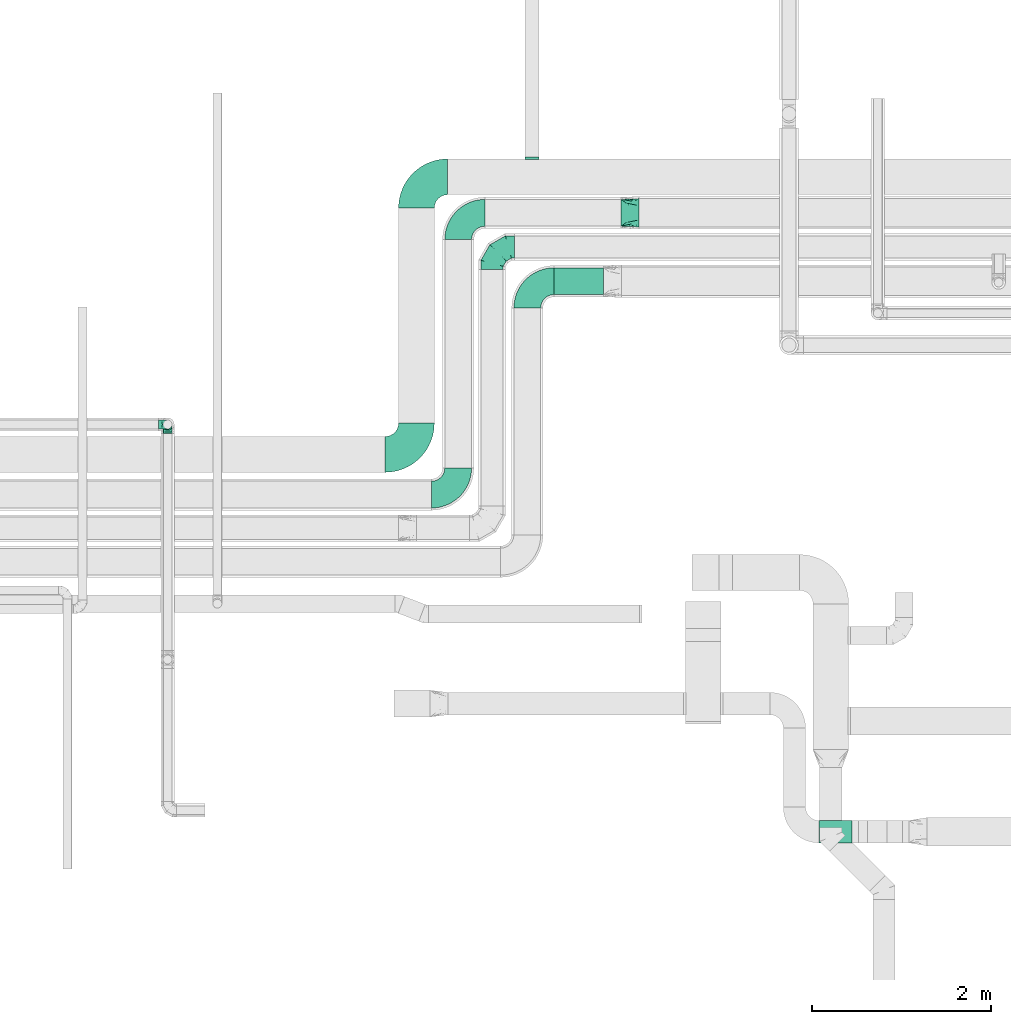
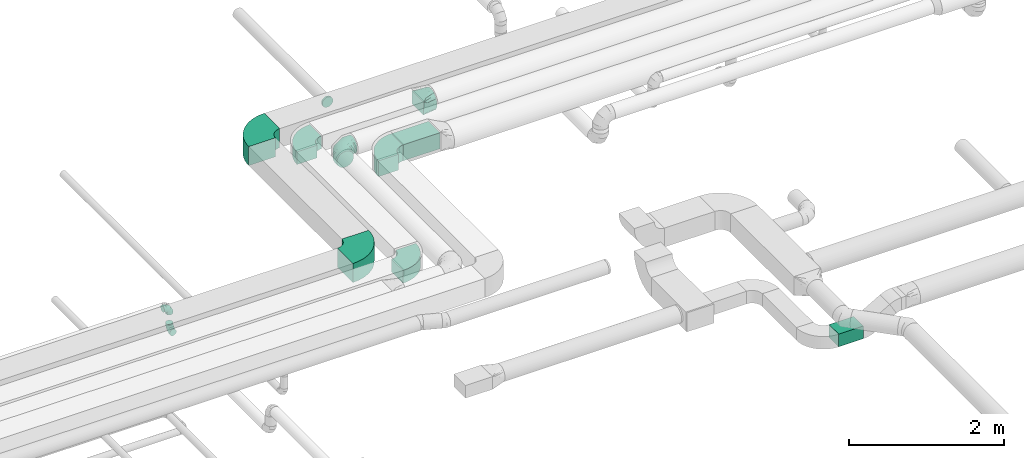
# One storey, part 44 of 92: 10 flow fittings, 2 flow segments.
"""IFC2X3 building model written with IfcOpenShell, lengths in millimetres."""

from ifc_helpers import new_model, entity, si_unit, converted_unit, derived_unit, direction, frame, frame_2d, origin, origin_2d_with_axis, place, context, subcontext, project, spatial, polyline, circle_curve, parameter, trimmed, segment, composite_curve, rectangle, outline, extrude, faceted_brep, source, transform, mapped, material, type_object, type_shapes, element, save


model = new_model("IFC2X3")

# Units and contexts
model_context = context("Model", 3, precision=0.01, world=origin(), true_north=direction((6.12303176911189e-17, 1.0)))
body_context = subcontext(model_context, "Body", "Model", "MODEL_VIEW")
ifc_project = project(units=[si_unit("LENGTHUNIT", "METRE", prefix="MILLI"), si_unit("AREAUNIT", "SQUARE_METRE"), si_unit("VOLUMEUNIT", "CUBIC_METRE"), converted_unit("PLANEANGLEUNIT", "DEGREE", entity("IfcRatioMeasure", 0.0174532925199433), si_unit("PLANEANGLEUNIT", "RADIAN"), dimensions=[0, 0, 0, 0, 0, 0, 0]), si_unit("MASSUNIT", "GRAM", prefix="KILO"), derived_unit("MASSDENSITYUNIT", [(si_unit("MASSUNIT", "GRAM", prefix="KILO"), 1), (si_unit("LENGTHUNIT", "METRE"), -3)]), derived_unit("MOMENTOFINERTIAUNIT", [(si_unit("LENGTHUNIT", "METRE"), 4)]), si_unit("TIMEUNIT", "SECOND"), si_unit("FREQUENCYUNIT", "HERTZ"), si_unit("THERMODYNAMICTEMPERATUREUNIT", "DEGREE_CELSIUS"), derived_unit("THERMALTRANSMITTANCEUNIT", [(si_unit("MASSUNIT", "GRAM", prefix="KILO"), 1), (si_unit("THERMODYNAMICTEMPERATUREUNIT", "KELVIN"), -1), (si_unit("TIMEUNIT", "SECOND"), -3)]), derived_unit("VOLUMETRICFLOWRATEUNIT", [(si_unit("LENGTHUNIT", "METRE"), 3), (si_unit("TIMEUNIT", "SECOND"), -1)]), derived_unit("MASSFLOWRATEUNIT", [(si_unit("MASSUNIT", "GRAM", prefix="KILO"), 1), (si_unit("TIMEUNIT", "SECOND"), -1)]), derived_unit("ROTATIONALFREQUENCYUNIT", [(si_unit("TIMEUNIT", "SECOND"), -1)]), si_unit("ELECTRICCURRENTUNIT", "AMPERE"), si_unit("ELECTRICVOLTAGEUNIT", "VOLT"), si_unit("POWERUNIT", "WATT"), si_unit("FORCEUNIT", "NEWTON", prefix="KILO"), si_unit("ILLUMINANCEUNIT", "LUX"), si_unit("LUMINOUSFLUXUNIT", "LUMEN"), si_unit("LUMINOUSINTENSITYUNIT", "CANDELA"), derived_unit("USERDEFINED", [(si_unit("MASSUNIT", "GRAM", prefix="KILO"), -1), (si_unit("LENGTHUNIT", "METRE"), -2), (si_unit("TIMEUNIT", "SECOND"), 3), (si_unit("LUMINOUSFLUXUNIT", "LUMEN"), 1)]), derived_unit("LINEARVELOCITYUNIT", [(si_unit("LENGTHUNIT", "METRE"), 1), (si_unit("TIMEUNIT", "SECOND"), -1)]), si_unit("PRESSUREUNIT", "PASCAL"), derived_unit("USERDEFINED", [(si_unit("LENGTHUNIT", "METRE"), -2), (si_unit("MASSUNIT", "GRAM", prefix="KILO"), 1), (si_unit("TIMEUNIT", "SECOND"), -2)]), derived_unit("LINEARFORCEUNIT", [(si_unit("MASSUNIT", "GRAM", prefix="KILO"), 1), (si_unit("LENGTHUNIT", "METRE"), 1), (si_unit("TIMEUNIT", "SECOND"), -2), (si_unit("LENGTHUNIT", "METRE"), -1)]), derived_unit("PLANARFORCEUNIT", [(si_unit("MASSUNIT", "GRAM", prefix="KILO"), 1), (si_unit("LENGTHUNIT", "METRE"), 1), (si_unit("TIMEUNIT", "SECOND"), -2), (si_unit("LENGTHUNIT", "METRE"), -2)])], contexts=[model_context])

# Site, building, storey
site_placement = place(None, origin())
site = spatial("IfcSite", under=ifc_project, at=site_placement, CompositionType="ELEMENT")
building_placement = place(site_placement, origin())
building = spatial("IfcBuilding", under=site, at=building_placement, CompositionType="ELEMENT")
storey_placement = place(building_placement, frame((0.0, 0.0, 4200.0)))
storey = spatial("IfcBuildingStorey", under=building, at=storey_placement, CompositionType="ELEMENT", Elevation=4200.0)

# Flow segments
duct_segment_type = type_object("IfcDuctSegmentType", PredefinedType="NOTDEFINED")
flow_segment_1_placement = place(storey_placement, frame((26228.23, 8674.98, 2950.0)))
element("IfcFlowSegment", 1, at=flow_segment_1_placement, inside=storey, type_object=duct_segment_type, context=body_context, shape_type="SweptSolid", body=[
    extrude(rectangle(XDim=368.802712652483, YDim=249.999999999999, at=origin_2d_with_axis()), frame((184.4, 125.0, 0.0)), (0.0, 0.0, 1.0), 200.0),
])
flow_segment_2_placement = place(storey_placement, frame((23265.08, 14807.0, 3200.0)))
element("IfcFlowSegment", 2, at=flow_segment_2_placement, inside=storey, type_object=duct_segment_type, context=body_context, shape_type="SweptSolid", body=[
    extrude(rectangle(XDim=554.647530360597, YDim=299.999999999999, at=origin_2d_with_axis()), frame((277.32, 150.0, 0.0)), (0.0, 0.0, 1.0), 249.999999999999),
])

# Flow fittings
ifc_material = material()
duct_fitting_type_1 = type_object("IfcDuctFittingType", PredefinedType="NOTDEFINED", material=ifc_material)
shared_shape_1 = source(origin(), body_context, "Body", "Brep", [
    faceted_brep([(-100.0, 0.0, -50.0), (-100.0, -12.94, -48.3), (-100.0, -25.0, -43.3), (-100.0, -35.36, -35.36), (-100.0, -43.3, -25.0), (-100.0, -48.3, -12.94), (-100.0, -50.0, 0.0), (-100.0, -48.3, 12.94), (-100.0, -43.3, 25.0), (-100.0, -35.36, 35.36), (-100.0, -25.0, 43.3), (-100.0, -12.94, 48.3), (-100.0, 0.0, 50.0), (-100.0, 12.94, 48.3), (-100.0, 25.0, 43.3), (-100.0, 35.36, 35.36), (-100.0, 43.3, 25.0), (-100.0, 48.3, 12.94), (-100.0, 50.0, 0.0), (-100.0, 48.3, -12.94), (-100.0, 43.3, -25.0), (-100.0, 35.36, -35.36), (-100.0, 25.0, -43.3), (-100.0, 12.94, -48.3), (-76.67, 12.94, 48.3), (-79.9, 25.0, 43.3), (-73.21, 0.0, 50.0), (-82.68, 35.36, 35.36), (-86.15, 48.3, 12.94), (-86.6, 50.0, 0.0), (-84.81, 43.3, 25.0), (-84.81, 43.3, -25.0), (-82.68, 35.36, -35.36), (-86.15, 48.3, -12.94), (-76.67, 12.94, -48.3), (-73.21, 0.0, -50.0), (-79.9, 25.0, -43.3), (-69.74, -12.94, -48.3), (-66.51, -25.0, -43.3), (-63.73, -35.36, -35.36), (-61.6, -43.3, -25.0), (-60.26, -48.3, -12.94), (-59.81, -50.0, 0.0), (-60.26, -48.3, 12.94), (-61.6, -43.3, 25.0), (-63.73, -35.36, 35.36), (-66.51, -25.0, 43.3), (-69.74, -12.94, 48.3), (-36.27, 36.27, 48.3), (-45.1, 45.1, 43.3), (-26.79, 26.79, 50.0), (-52.68, 52.68, 35.36), (-58.49, 58.49, 25.0), (-62.15, 62.15, 12.94), (-63.4, 63.4, 0.0), (-62.15, 62.15, -12.94), (-58.49, 58.49, -25.0), (-52.68, 52.68, -35.36), (-36.27, 36.27, -48.3), (-26.79, 26.79, -50.0), (-45.1, 45.1, -43.3), (-17.32, 17.32, -48.3), (-8.49, 8.49, -43.3), (-0.91, 0.91, -35.36), (4.9, -4.9, -25.0), (8.56, -8.56, -12.94), (9.81, -9.81, 0.0), (8.56, -8.56, 12.94), (4.9, -4.9, 25.0), (-0.91, 0.91, 35.36), (-8.49, 8.49, 43.3), (-17.32, 17.32, 48.3), (-12.94, 76.67, 48.3), (-25.0, 79.9, 43.3), (0.0, 73.21, 50.0), (-35.36, 82.68, 35.36), (-43.3, 84.81, 25.0), (-48.3, 86.15, 12.94), (-50.0, 86.6, 0.0), (-48.3, 86.15, -12.94), (-43.3, 84.81, -25.0), (-35.36, 82.68, -35.36), (-12.94, 76.67, -48.3), (0.0, 73.21, -50.0), (-25.0, 79.9, -43.3), (12.94, 69.74, -48.3), (25.0, 66.51, -43.3), (35.36, 63.73, -35.36), (43.3, 61.6, -25.0), (48.3, 60.26, -12.94), (50.0, 59.81, 0.0), (48.3, 60.26, 12.94), (43.3, 61.6, 25.0), (35.36, 63.73, 35.36), (25.0, 66.51, 43.3), (12.94, 69.74, 48.3), (-12.94, 100.0, -48.3), (-25.0, 100.0, -43.3), (-35.36, 100.0, -35.36), (-43.3, 100.0, -25.0), (-48.3, 100.0, -12.94), (-50.0, 100.0, 0.0), (-48.3, 100.0, 12.94), (-43.3, 100.0, 25.0), (-35.36, 100.0, 35.36), (-25.0, 100.0, 43.3), (-12.94, 100.0, 48.3), (0.0, 100.0, 50.0), (12.94, 100.0, 48.3), (25.0, 100.0, 43.3), (35.36, 100.0, 35.36), (43.3, 100.0, 25.0), (48.3, 100.0, 12.94), (50.0, 100.0, 0.0), (48.3, 100.0, -12.94), (43.3, 100.0, -25.0), (35.36, 100.0, -35.36), (25.0, 100.0, -43.3), (12.94, 100.0, -48.3), (0.0, 100.0, -50.0)], [[[0, 1, 2, 3, 4, 5, 6, 7, 8, 9, 10, 11, 12, 13, 14, 15, 16, 17, 18, 19, 20, 21, 22, 23]], [[24, 25, 14, 13]], [[26, 24, 13, 12]], [[14, 25, 27, 15]], [[28, 29, 18, 17]], [[30, 28, 17, 16]], [[15, 27, 30, 16]], [[20, 31, 32, 21]], [[33, 31, 20, 19]], [[18, 29, 33, 19]], [[34, 35, 0, 23]], [[36, 34, 23, 22]], [[32, 36, 22, 21]], [[2, 1, 37, 38]], [[3, 2, 38, 39]], [[0, 35, 37, 1]], [[5, 4, 40, 41]], [[6, 5, 41, 42]], [[3, 39, 40, 4]], [[6, 42, 43, 7]], [[7, 43, 44, 8]], [[8, 44, 45, 9]], [[10, 46, 47, 11]], [[11, 47, 26, 12]], [[10, 9, 45, 46]], [[48, 49, 25, 24]], [[50, 48, 24, 26]], [[27, 25, 49, 51]], [[52, 53, 28, 30]], [[51, 52, 30, 27]], [[29, 28, 53, 54]], [[55, 56, 31, 33]], [[54, 55, 33, 29]], [[57, 32, 31, 56]], [[58, 59, 35, 34]], [[60, 58, 34, 36]], [[57, 60, 36, 32]], [[37, 35, 59, 61]], [[38, 37, 61, 62]], [[39, 38, 62, 63]], [[41, 40, 64, 65]], [[42, 41, 65, 66]], [[63, 64, 40, 39]], [[43, 42, 66, 67]], [[44, 43, 67, 68]], [[68, 69, 45, 44]], [[46, 45, 69, 70]], [[47, 46, 70, 71]], [[26, 47, 71, 50]], [[72, 73, 49, 48]], [[74, 72, 48, 50]], [[51, 49, 73, 75]], [[76, 77, 53, 52]], [[75, 76, 52, 51]], [[54, 53, 77, 78]], [[79, 80, 56, 55]], [[78, 79, 55, 54]], [[81, 57, 56, 80]], [[82, 83, 59, 58]], [[84, 82, 58, 60]], [[81, 84, 60, 57]], [[61, 59, 83, 85]], [[62, 61, 85, 86]], [[63, 62, 86, 87]], [[65, 64, 88, 89]], [[66, 65, 89, 90]], [[87, 88, 64, 63]], [[67, 66, 90, 91]], [[68, 67, 91, 92]], [[92, 93, 69, 68]], [[70, 69, 93, 94]], [[71, 70, 94, 95]], [[50, 71, 95, 74]], [[96, 97, 98, 99, 100, 101, 102, 103, 104, 105, 106, 107, 108, 109, 110, 111, 112, 113, 114, 115, 116, 117, 118, 119]], [[72, 74, 107, 106]], [[73, 72, 106, 105]], [[75, 73, 105, 104]], [[77, 76, 103, 102]], [[78, 77, 102, 101]], [[75, 104, 103, 76]], [[78, 101, 100, 79]], [[79, 100, 99, 80]], [[80, 99, 98, 81]], [[96, 119, 83, 82]], [[97, 96, 82, 84]], [[84, 81, 98, 97]], [[83, 119, 118, 85]], [[85, 118, 117, 86]], [[86, 117, 116, 87]], [[88, 115, 114, 89]], [[89, 114, 113, 90]], [[87, 116, 115, 88]], [[91, 90, 113, 112]], [[92, 91, 112, 111]], [[93, 92, 111, 110]], [[95, 94, 109, 108]], [[74, 95, 108, 107]], [[110, 109, 94, 93]]]),
])
type_shapes(duct_fitting_type_1, [shared_shape_1])
for number, where, z_axis, x_axis in (
    (3, (18942.06, 13354.28, 2950.0), (1.0, 0.0, 0.0), (0.0, 1.0, 0.0)),
    (4, (18942.06, 13354.28, 3300.0), (0.0, -1.0, 0.0), (0.0, 0.0, 1.0)),
):
    element("IfcFlowFitting", number, at=place(storey_placement, frame(where, z_axis=z_axis, x_axis=x_axis)), inside=storey, type_object=duct_fitting_type_1, material=ifc_material, context=body_context, shape_type="MappedRepresentation", body=[
        mapped(shared_shape_1, transform((0.0, 0.0, 0.0), scale=1.0)),
    ])
duct_fitting_type_2 = type_object("IfcDuctFittingType", PredefinedType="NOTDEFINED", material=ifc_material)
shared_shape_2 = source(origin(), body_context, "Body", "Brep", [
    faceted_brep([(-250.0, 0.0, -125.0), (-250.0, -32.35, -120.74), (-250.0, -62.5, -108.25), (-250.0, -88.39, -88.39), (-250.0, -108.25, -62.5), (-250.0, -120.74, -32.35), (-250.0, -125.0, 0.0), (-250.0, -120.74, 32.35), (-250.0, -108.25, 62.5), (-250.0, -88.39, 88.39), (-250.0, -62.5, 108.25), (-250.0, -32.35, 120.74), (-250.0, 0.0, 125.0), (-250.0, 32.35, 120.74), (-250.0, 62.5, 108.25), (-250.0, 88.39, 88.39), (-250.0, 108.25, 62.5), (-250.0, 120.74, 32.35), (-250.0, 125.0, 0.0), (-250.0, 120.74, -32.35), (-250.0, 108.25, -62.5), (-250.0, 88.39, -88.39), (-250.0, 62.5, -108.25), (-250.0, 32.35, -120.74), (-191.68, 32.35, 120.74), (-199.76, 62.5, 108.25), (-183.01, 0.0, 125.0), (-206.7, 88.39, 88.39), (-215.37, 120.74, 32.35), (-216.51, 125.0, 0.0), (-212.02, 108.25, 62.5), (-212.02, 108.25, -62.5), (-206.7, 88.39, -88.39), (-215.37, 120.74, -32.35), (-191.68, 32.35, -120.74), (-183.01, 0.0, -125.0), (-199.76, 62.5, -108.25), (-174.34, -32.35, -120.74), (-166.27, -62.5, -108.25), (-159.33, -88.39, -88.39), (-154.01, -108.25, -62.5), (-150.66, -120.74, -32.35), (-149.52, -125.0, 0.0), (-150.66, -120.74, 32.35), (-154.01, -108.25, 62.5), (-159.33, -88.39, 88.39), (-166.27, -62.5, 108.25), (-174.34, -32.35, 120.74), (-90.67, 90.67, 120.74), (-112.74, 112.74, 108.25), (-66.99, 66.99, 125.0), (-131.69, 131.69, 88.39), (-146.23, 146.23, 62.5), (-155.38, 155.38, 32.35), (-158.49, 158.49, 0.0), (-155.38, 155.38, -32.35), (-146.23, 146.23, -62.5), (-131.69, 131.69, -88.39), (-90.67, 90.67, -120.74), (-66.99, 66.99, -125.0), (-112.74, 112.74, -108.25), (-43.3, 43.3, -120.74), (-21.23, 21.23, -108.25), (-2.28, 2.28, -88.39), (12.26, -12.26, -62.5), (21.4, -21.4, -32.35), (24.52, -24.52, 0.0), (21.4, -21.4, 32.35), (12.26, -12.26, 62.5), (-2.28, 2.28, 88.39), (-21.23, 21.23, 108.25), (-43.3, 43.3, 120.74), (-32.35, 191.68, 120.74), (-62.5, 199.76, 108.25), (0.0, 183.01, 125.0), (-88.39, 206.7, 88.39), (-108.25, 212.02, 62.5), (-120.74, 215.37, 32.35), (-125.0, 216.51, 0.0), (-120.74, 215.37, -32.35), (-108.25, 212.02, -62.5), (-88.39, 206.7, -88.39), (-32.35, 191.68, -120.74), (0.0, 183.01, -125.0), (-62.5, 199.76, -108.25), (32.35, 174.34, -120.74), (62.5, 166.27, -108.25), (88.39, 159.33, -88.39), (108.25, 154.01, -62.5), (120.74, 150.66, -32.35), (125.0, 149.52, 0.0), (120.74, 150.66, 32.35), (108.25, 154.01, 62.5), (88.39, 159.33, 88.39), (62.5, 166.27, 108.25), (32.35, 174.34, 120.74), (-32.35, 250.0, -120.74), (-62.5, 250.0, -108.25), (-88.39, 250.0, -88.39), (-108.25, 250.0, -62.5), (-120.74, 250.0, -32.35), (-125.0, 250.0, 0.0), (-120.74, 250.0, 32.35), (-108.25, 250.0, 62.5), (-88.39, 250.0, 88.39), (-62.5, 250.0, 108.25), (-32.35, 250.0, 120.74), (0.0, 250.0, 125.0), (32.35, 250.0, 120.74), (62.5, 250.0, 108.25), (88.39, 250.0, 88.39), (108.25, 250.0, 62.5), (120.74, 250.0, 32.35), (125.0, 250.0, 0.0), (120.74, 250.0, -32.35), (108.25, 250.0, -62.5), (88.39, 250.0, -88.39), (62.5, 250.0, -108.25), (32.35, 250.0, -120.74), (0.0, 250.0, -125.0)], [[[0, 1, 2, 3, 4, 5, 6, 7, 8, 9, 10, 11, 12, 13, 14, 15, 16, 17, 18, 19, 20, 21, 22, 23]], [[24, 25, 14, 13]], [[26, 24, 13, 12]], [[14, 25, 27, 15]], [[28, 29, 18, 17]], [[30, 28, 17, 16]], [[15, 27, 30, 16]], [[20, 31, 32, 21]], [[33, 31, 20, 19]], [[18, 29, 33, 19]], [[34, 35, 0, 23]], [[36, 34, 23, 22]], [[21, 32, 36, 22]], [[1, 0, 35, 37]], [[2, 1, 37, 38]], [[38, 39, 3, 2]], [[5, 4, 40, 41]], [[6, 5, 41, 42]], [[39, 40, 4, 3]], [[6, 42, 43, 7]], [[7, 43, 44, 8]], [[8, 44, 45, 9]], [[9, 45, 46, 10]], [[10, 46, 47, 11]], [[26, 12, 11, 47]], [[48, 49, 25, 24]], [[50, 48, 24, 26]], [[27, 25, 49, 51]], [[52, 53, 28, 30]], [[51, 52, 30, 27]], [[29, 28, 53, 54]], [[55, 56, 31, 33]], [[54, 55, 33, 29]], [[32, 31, 56, 57]], [[58, 59, 35, 34]], [[60, 58, 34, 36]], [[57, 60, 36, 32]], [[37, 35, 59, 61]], [[38, 37, 61, 62]], [[39, 38, 62, 63]], [[41, 40, 64, 65]], [[42, 41, 65, 66]], [[63, 64, 40, 39]], [[43, 42, 66, 67]], [[44, 43, 67, 68]], [[68, 69, 45, 44]], [[46, 45, 69, 70]], [[47, 46, 70, 71]], [[26, 47, 71, 50]], [[72, 73, 49, 48]], [[74, 72, 48, 50]], [[51, 49, 73, 75]], [[76, 77, 53, 52]], [[75, 76, 52, 51]], [[54, 53, 77, 78]], [[79, 80, 56, 55]], [[78, 79, 55, 54]], [[57, 56, 80, 81]], [[82, 83, 59, 58]], [[84, 82, 58, 60]], [[81, 84, 60, 57]], [[61, 59, 83, 85]], [[62, 61, 85, 86]], [[63, 62, 86, 87]], [[65, 64, 88, 89]], [[66, 65, 89, 90]], [[87, 88, 64, 63]], [[67, 66, 90, 91]], [[68, 67, 91, 92]], [[92, 93, 69, 68]], [[70, 69, 93, 94]], [[71, 70, 94, 95]], [[50, 71, 95, 74]], [[96, 97, 98, 99, 100, 101, 102, 103, 104, 105, 106, 107, 108, 109, 110, 111, 112, 113, 114, 115, 116, 117, 118, 119]], [[72, 74, 107, 106]], [[73, 72, 106, 105]], [[75, 73, 105, 104]], [[77, 76, 103, 102]], [[78, 77, 102, 101]], [[75, 104, 103, 76]], [[78, 101, 100, 79]], [[79, 100, 99, 80]], [[80, 99, 98, 81]], [[84, 97, 96, 82]], [[82, 96, 119, 83]], [[84, 81, 98, 97]], [[83, 119, 118, 85]], [[85, 118, 117, 86]], [[116, 87, 86, 117]], [[88, 115, 114, 89]], [[89, 114, 113, 90]], [[115, 88, 87, 116]], [[91, 90, 113, 112]], [[92, 91, 112, 111]], [[111, 110, 93, 92]], [[95, 94, 109, 108]], [[74, 95, 108, 107]], [[110, 109, 94, 93]]]),
])
type_shapes(duct_fitting_type_2, [shared_shape_2])
flow_fitting_1_placement = place(storey_placement, frame((22570.98, 15339.5, 3300.0), z_axis=(0.0, 0.0, 1.0), x_axis=(-1.0, 0.0, 0.0)))
element("IfcFlowFitting", 5, at=flow_fitting_1_placement, inside=storey, type_object=duct_fitting_type_2, material=ifc_material, context=body_context, shape_type="MappedRepresentation", body=[
    mapped(shared_shape_2, transform((0.0, 0.0, 0.0), scale=1.0)),
])
duct_fitting_type_3 = type_object("IfcDuctFittingType", PredefinedType="NOTDEFINED", material=ifc_material)
shared_shape_3 = source(origin(), body_context, "Body", "Brep", [
    faceted_brep([(200.0, 78.75, 136.4), (200.0, 59.76, 144.27), (200.0, 40.76, 152.13), (200.0, 27.93, 153.82), (200.0, 15.1, 155.51), (200.0, 0.0, 157.5), (200.0, -15.1, 155.51), (200.0, -27.93, 153.82), (200.0, -40.76, 152.13), (200.0, -59.76, 144.27), (200.0, -78.75, 136.4), (200.0, -95.06, 123.88), (200.0, -111.37, 111.37), (200.0, -123.88, 95.06), (200.0, -136.4, 78.75), (200.0, -144.27, 59.76), (200.0, -152.13, 40.76), (200.0, -153.82, 27.93), (200.0, -155.51, 15.1), (200.0, -157.5, 0.0), (200.0, -155.51, -15.1), (200.0, -153.82, -27.93), (200.0, -152.13, -40.76), (200.0, -144.27, -59.76), (200.0, -136.4, -78.75), (200.0, -123.88, -95.06), (200.0, -111.37, -111.37), (200.0, -95.06, -123.88), (200.0, -78.75, -136.4), (200.0, -59.76, -144.27), (200.0, -40.76, -152.13), (200.0, -27.93, -153.82), (200.0, -15.1, -155.51), (200.0, 0.0, -157.5), (200.0, 15.1, -155.51), (200.0, 27.93, -153.82), (200.0, 40.76, -152.13), (200.0, 59.76, -144.27), (200.0, 78.75, -136.4), (200.0, 95.06, -123.88), (200.0, 111.37, -111.37), (200.0, 123.88, -95.06), (200.0, 136.4, -78.75), (200.0, 144.27, -59.76), (200.0, 152.13, -40.76), (200.0, 153.82, -27.93), (200.0, 155.51, -15.1), (200.0, 157.5, 0.0), (200.0, 155.51, 15.1), (200.0, 153.82, 27.93), (200.0, 152.13, 40.76), (200.0, 144.27, 59.76), (200.0, 136.4, 78.75), (200.0, 123.88, 95.06), (200.0, 111.37, 111.37), (200.0, 95.06, 123.88), (0.0, -150.0, 100.0), (0.0, 150.0, 100.0), (0.0, 150.0, -100.0), (0.0, -150.0, -100.0), (128.09, -53.94, 136.82), (104.11, -71.91, 129.93), (78.09, -91.44, 122.45), (100.0, -127.21, 108.95), (26.03, -130.48, 107.48), (52.06, -151.95, 73.97), (26.03, -150.98, 86.99), (78.09, -152.93, 60.96), (104.11, -153.9, 47.94), (128.09, -154.8, 35.96), (176.03, -17.98, 150.61), (152.06, -35.96, 143.72), (152.06, -155.7, 23.97), (176.03, -156.6, 11.99), (52.06, -110.96, 114.97), (26.03, -150.98, -86.99), (52.06, -151.95, -73.97), (78.09, -152.93, -60.96), (104.11, -153.9, -47.94), (128.09, -154.8, -35.96), (152.06, -155.7, -23.97), (176.03, -156.6, -11.99), (100.0, -133.95, -102.21), (52.06, -110.96, -114.97), (26.03, -130.48, -107.48), (78.09, -91.44, -122.45), (104.11, -71.91, -129.93), (128.09, -53.94, -136.82), (152.06, -35.96, -143.72), (176.03, -17.98, -150.61), (26.03, 130.48, -107.48), (52.06, 110.96, -114.97), (78.09, 91.44, -122.45), (104.11, 71.91, -129.93), (128.09, 53.94, -136.82), (152.06, 35.96, -143.72), (176.03, 17.98, -150.61), (100.0, 127.21, -108.95), (52.06, 151.95, -73.97), (26.03, 150.98, -86.99), (78.09, 152.93, -60.96), (104.11, 153.9, -47.94), (128.09, 154.8, -35.96), (152.06, 155.7, -23.97), (176.03, 156.6, -11.99), (26.03, 150.98, 86.99), (52.06, 151.95, 73.97), (78.09, 152.93, 60.96), (104.11, 153.9, 47.94), (128.09, 154.8, 35.96), (152.06, 155.7, 23.97), (176.03, 156.6, 11.99), (100.0, 133.95, 102.21), (52.06, 110.96, 114.97), (26.03, 130.48, 107.48), (78.09, 91.44, 122.45), (104.11, 71.91, 129.93), (128.09, 53.94, 136.82), (152.06, 35.96, 143.72), (176.03, 17.98, 150.61)], [[[0, 1, 2, 3, 4, 5, 6, 7, 8, 9, 10, 11, 12, 13, 14, 15, 16, 17, 18, 19, 20, 21, 22, 23, 24, 25, 26, 27, 28, 29, 30, 31, 32, 33, 34, 35, 36, 37, 38, 39, 40, 41, 42, 43, 44, 45, 46, 47, 48, 49, 50, 51, 52, 53, 54, 55]], [[56, 57, 58, 59]], [[60, 61, 62, 9]], [[63, 11, 64]], [[13, 12, 63]], [[8, 60, 9]], [[9, 62, 10]], [[65, 14, 13]], [[13, 63, 66]], [[15, 67, 68, 69]], [[70, 71, 60, 8, 7, 6, 5]], [[17, 16, 69, 72, 73, 19, 18]], [[15, 14, 67]], [[15, 69, 16]], [[14, 65, 67]], [[11, 74, 64]], [[11, 10, 74]], [[56, 63, 64]], [[11, 63, 12]], [[13, 66, 65]], [[63, 56, 66]], [[62, 74, 10]], [[73, 72, 69, 68, 67, 65, 66, 56, 59, 75, 76, 77, 78, 79, 80, 81, 19]], [[79, 78, 77, 23]], [[82, 25, 75]], [[27, 26, 82]], [[22, 79, 23]], [[23, 77, 24]], [[83, 28, 27]], [[27, 82, 84]], [[29, 85, 86, 87]], [[81, 80, 79, 22, 21, 20, 19]], [[31, 30, 87, 88, 89, 33, 32]], [[29, 28, 85]], [[29, 87, 30]], [[28, 83, 85]], [[25, 76, 75]], [[25, 24, 76]], [[59, 82, 75]], [[25, 82, 26]], [[27, 84, 83]], [[82, 59, 84]], [[77, 76, 24]], [[89, 88, 87, 86, 85, 83, 84, 59, 58, 90, 91, 92, 93, 94, 95, 96, 33]], [[94, 93, 92, 37]], [[97, 39, 90]], [[41, 40, 97]], [[36, 94, 37]], [[37, 92, 38]], [[98, 42, 41]], [[41, 97, 99]], [[43, 100, 101, 102]], [[96, 95, 94, 36, 35, 34, 33]], [[45, 44, 102, 103, 104, 47, 46]], [[43, 42, 100]], [[43, 102, 44]], [[42, 98, 100]], [[39, 91, 90]], [[39, 38, 91]], [[58, 97, 90]], [[39, 97, 40]], [[41, 99, 98]], [[97, 58, 99]], [[92, 91, 38]], [[58, 57, 105, 106, 107, 108, 109, 110, 111, 47, 104, 103, 102, 101, 100, 98, 99]], [[109, 108, 107, 51]], [[112, 53, 105]], [[55, 54, 112]], [[50, 109, 51]], [[51, 107, 52]], [[113, 0, 55]], [[55, 112, 114]], [[1, 115, 116, 117]], [[111, 110, 109, 50, 49, 48, 47]], [[3, 2, 117, 118, 119, 5, 4]], [[1, 0, 115]], [[1, 117, 2]], [[0, 113, 115]], [[53, 106, 105]], [[53, 52, 106]], [[57, 112, 105]], [[53, 112, 54]], [[55, 114, 113]], [[112, 57, 114]], [[107, 106, 52]], [[57, 56, 64, 74, 62, 61, 60, 71, 70, 5, 119, 118, 117, 116, 115, 113, 114]]]),
])
type_shapes(duct_fitting_type_3, [shared_shape_3])
flow_fitting_2_placement = place(storey_placement, frame((24015.14, 15722.0, 3300.0)))
element("IfcFlowFitting", 6, at=flow_fitting_2_placement, inside=storey, type_object=duct_fitting_type_3, material=ifc_material, context=body_context, shape_type="MappedRepresentation", body=[
    mapped(shared_shape_3, transform((0.0, 0.0, 0.0), scale=1.0)),
])
duct_fitting_type_4 = type_object("IfcDuctFittingType", PredefinedType="NOTDEFINED", material=ifc_material)
shared_shape_4 = source(origin(), body_context, "Body", "Brep", [
    faceted_brep([(20.0, 20.71, -77.27), (20.0, 40.0, -69.28), (20.0, 56.57, -56.57), (20.0, 69.28, -40.0), (20.0, 77.27, -20.71), (20.0, 80.0, 0.0), (20.0, 77.27, 20.71), (20.0, 69.28, 40.0), (20.0, 56.57, 56.57), (20.0, 40.0, 69.28), (20.0, 20.71, 77.27), (20.0, 0.0, 80.0), (20.0, -20.71, 77.27), (20.0, -40.0, 69.28), (20.0, -56.57, 56.57), (20.0, -69.28, 40.0), (20.0, -77.27, 20.71), (20.0, -80.0, 0.0), (20.0, -77.27, -20.71), (20.0, -69.28, -40.0), (20.0, -56.57, -56.57), (20.0, -40.0, -69.28), (20.0, -20.71, -77.27), (20.0, 0.0, -80.0), (0.0, 0.0, 80.0), (0.0, 20.71, 77.27), (-6.1, 20.71, 77.27), (-6.1, 0.0, 80.0), (0.0, 40.0, 69.28), (-6.1, 40.0, 69.28), (0.0, 56.57, 56.57), (-6.1, 56.57, 56.57), (0.0, 69.28, 40.0), (0.0, 77.27, 20.71), (-6.1, 77.27, 20.71), (-6.1, 69.28, 40.0), (0.0, 80.0, 0.0), (-6.1, 80.0, 0.0), (0.0, 77.27, -20.71), (-6.1, 77.27, -20.71), (0.0, 69.28, -40.0), (-6.1, 69.28, -40.0), (0.0, 56.57, -56.57), (-6.1, 56.57, -56.57), (0.0, 40.0, -69.28), (0.0, 20.71, -77.27), (-6.1, 20.71, -77.27), (-6.1, 40.0, -69.28), (0.0, 0.0, -80.0), (-6.1, 0.0, -80.0), (0.0, -20.71, -77.27), (-6.1, -20.71, -77.27), (0.0, -40.0, -69.28), (-6.1, -40.0, -69.28), (0.0, -56.57, -56.57), (-6.1, -56.57, -56.57), (0.0, -69.28, -40.0), (0.0, -77.27, -20.71), (-6.1, -77.27, -20.71), (-6.1, -69.28, -40.0), (0.0, -80.0, 0.0), (-6.1, -80.0, 0.0), (0.0, -77.27, 20.71), (-6.1, -77.27, 20.71), (0.0, -69.28, 40.0), (-6.1, -69.28, 40.0), (0.0, -56.57, 56.57), (-6.1, -56.57, 56.57), (0.0, -40.0, 69.28), (0.0, -20.71, 77.27), (-6.1, -20.71, 77.27), (-6.1, -40.0, 69.28)], [[[0, 1, 2, 3, 4, 5, 6, 7, 8, 9, 10, 11, 12, 13, 14, 15, 16, 17, 18, 19, 20, 21, 22, 23]], [[24, 11, 10, 25, 26, 27]], [[25, 10, 9, 28, 29, 26]], [[28, 9, 8, 30, 31, 29]], [[32, 7, 6, 33, 34, 35]], [[33, 6, 5, 36, 37, 34]], [[30, 8, 7, 32, 35, 31]], [[36, 5, 4, 38, 39, 37]], [[38, 4, 3, 40, 41, 39]], [[40, 3, 2, 42, 43, 41]], [[44, 1, 0, 45, 46, 47]], [[45, 0, 23, 48, 49, 46]], [[42, 2, 1, 44, 47, 43]], [[48, 23, 22, 50, 51, 49]], [[50, 22, 21, 52, 53, 51]], [[52, 21, 20, 54, 55, 53]], [[56, 19, 18, 57, 58, 59]], [[57, 18, 17, 60, 61, 58]], [[54, 20, 19, 56, 59, 55]], [[60, 17, 16, 62, 63, 61]], [[62, 16, 15, 64, 65, 63]], [[64, 15, 14, 66, 67, 65]], [[68, 13, 12, 69, 70, 71]], [[69, 12, 11, 24, 27, 70]], [[66, 14, 13, 68, 71, 67]], [[49, 51, 53, 55, 59, 58, 61, 63, 65, 67, 71, 70, 27, 26, 29, 31, 35, 34, 37, 39, 41, 43, 47, 46]]]),
])
type_shapes(duct_fitting_type_4, [shared_shape_4])
flow_fitting_3_placement = place(storey_placement, frame((23016.62, 16324.51, 3300.0), z_axis=(0.0, 0.0, 1.0), x_axis=(0.0, 1.0, 0.0)))
element("IfcFlowFitting", 7, at=flow_fitting_3_placement, inside=storey, type_object=duct_fitting_type_4, material=ifc_material, context=body_context, shape_type="MappedRepresentation", body=[
    mapped(shared_shape_4, transform((0.0, 0.0, 0.0), scale=1.0)),
])
duct_fitting_type_5 = type_object("IfcDuctFittingType", PredefinedType="NOTDEFINED", material=ifc_material)
shared_shape_5 = source(origin(), body_context, "Body", "SweptSolid", [
    extrude(outline(composite_curve([segment(polyline([(-300.0, -150.0), (0.0, -150.0)]), True, "CONTINUOUS"), segment(trimmed(circle_curve(frame_2d((150.0, -150.0), x_axis=(0.0, 1.0)), 150.0), [parameter(0.0)], [parameter(90.0)], True, "PARAMETER"), False, "CONTINUOUS"), segment(polyline([(150.0, 0.0), (150.0, 300.0)]), True, "CONTINUOUS"), segment(trimmed(circle_curve(frame_2d((150.0, -150.0), x_axis=(0.0, 1.0)), 450.0), [parameter(0.0)], [parameter(90.0000000000001)], True, "PARAMETER"), True, "CONTINUOUS")], self_intersect=False)), frame((-150.0, 150.0, -125.0), z_axis=(0.0, 0.0, 1.0), x_axis=(-1.0, 0.0, 0.0)), (0.0, 0.0, 1.0), 250.0),
])
type_shapes(duct_fitting_type_5, [shared_shape_5])
flow_fitting_4_placement = place(storey_placement, frame((22965.08, 14957.0, 3325.0), z_axis=(0.0, 0.0, 1.0), x_axis=(-1.0, 0.0, 0.0)))
element("IfcFlowFitting", 8, at=flow_fitting_4_placement, inside=storey, type_object=duct_fitting_type_5, material=ifc_material, context=body_context, shape_type="MappedRepresentation", body=[
    mapped(shared_shape_5, transform((0.0, 0.0, 0.0), scale=1.0)),
])
duct_fitting_type_6 = type_object("IfcDuctFittingType", PredefinedType="NOTDEFINED", material=ifc_material)
shared_shape_6 = source(origin(), body_context, "Body", "SweptSolid", [
    extrude(outline(composite_curve([segment(polyline([(-300.0, -150.0), (0.0, -150.0)]), True, "CONTINUOUS"), segment(trimmed(circle_curve(frame_2d((150.0, -150.0), x_axis=(0.0, 1.0)), 150.0), [parameter(0.0)], [parameter(90.0)], True, "PARAMETER"), False, "CONTINUOUS"), segment(polyline([(150.0, 0.0), (150.0, 300.0)]), True, "CONTINUOUS"), segment(trimmed(circle_curve(frame_2d((150.0, -150.0), x_axis=(0.0, 1.0)), 450.0), [parameter(0.0)], [parameter(90.0000000000001)], True, "PARAMETER"), True, "CONTINUOUS")], self_intersect=False)), frame((-150.0, 150.0, -100.0), z_axis=(0.0, 0.0, 1.0), x_axis=(-1.0, 0.0, 0.0)), (0.0, 0.0, 1.0), 200.0),
])
type_shapes(duct_fitting_type_6, [shared_shape_6])
flow_fitting_5_placement = place(storey_placement, frame((22192.16, 12569.66, 3300.0)))
element("IfcFlowFitting", 9, at=flow_fitting_5_placement, inside=storey, type_object=duct_fitting_type_6, material=ifc_material, context=body_context, shape_type="MappedRepresentation", body=[
    mapped(shared_shape_6, transform((0.0, 0.0, 0.0), scale=1.0)),
])
flow_fitting_6_placement = place(storey_placement, frame((22192.16, 15722.0, 3300.0), z_axis=(0.0, 0.0, 1.0), x_axis=(-1.0, 0.0, 0.0)))
element("IfcFlowFitting", 10, at=flow_fitting_6_placement, inside=storey, type_object=duct_fitting_type_6, material=ifc_material, context=body_context, shape_type="MappedRepresentation", body=[
    mapped(shared_shape_6, transform((0.0, 0.0, 0.0), scale=1.0)),
])
duct_fitting_type_7 = type_object("IfcDuctFittingType", PredefinedType="NOTDEFINED", material=ifc_material)
shared_shape_7 = source(origin(), body_context, "Body", "SweptSolid", [
    extrude(outline(composite_curve([segment(polyline([(-375.0, -175.0), (25.0, -175.0)]), True, "CONTINUOUS"), segment(trimmed(circle_curve(frame_2d((175.0, -175.0), x_axis=(0.0, 1.0)), 150.0), [parameter(0.0)], [parameter(90.0000000000001)], True, "PARAMETER"), False, "CONTINUOUS"), segment(polyline([(175.0, -25.0), (175.0, 375.0)]), True, "CONTINUOUS"), segment(trimmed(circle_curve(frame_2d((175.0, -175.0), x_axis=(0.0, 1.0)), 550.0), [parameter(0.0)], [parameter(90.0)], True, "PARAMETER"), True, "CONTINUOUS")], self_intersect=False)), frame((-175.0, 175.0, -150.0), z_axis=(0.0, 0.0, 1.0), x_axis=(-1.0, 0.0, 0.0)), (0.0, 0.0, 1.0), 300.0),
])
type_shapes(duct_fitting_type_7, [shared_shape_7])
flow_fitting_7_placement = place(storey_placement, frame((21725.0, 16124.51, 3300.0), z_axis=(0.0, 0.0, 1.0), x_axis=(-1.0, 0.0, 0.0)))
element("IfcFlowFitting", 11, at=flow_fitting_7_placement, inside=storey, type_object=duct_fitting_type_7, material=ifc_material, context=body_context, shape_type="MappedRepresentation", body=[
    mapped(shared_shape_7, transform((0.0, 0.0, 0.0), scale=1.0)),
])
flow_fitting_8_placement = place(storey_placement, frame((21725.0, 13019.63, 3300.0)))
element("IfcFlowFitting", 12, at=flow_fitting_8_placement, inside=storey, type_object=duct_fitting_type_7, material=ifc_material, context=body_context, shape_type="MappedRepresentation", body=[
    mapped(shared_shape_7, transform((0.0, 0.0, 0.0), scale=1.0)),
])

save(model, "model.ifc")
